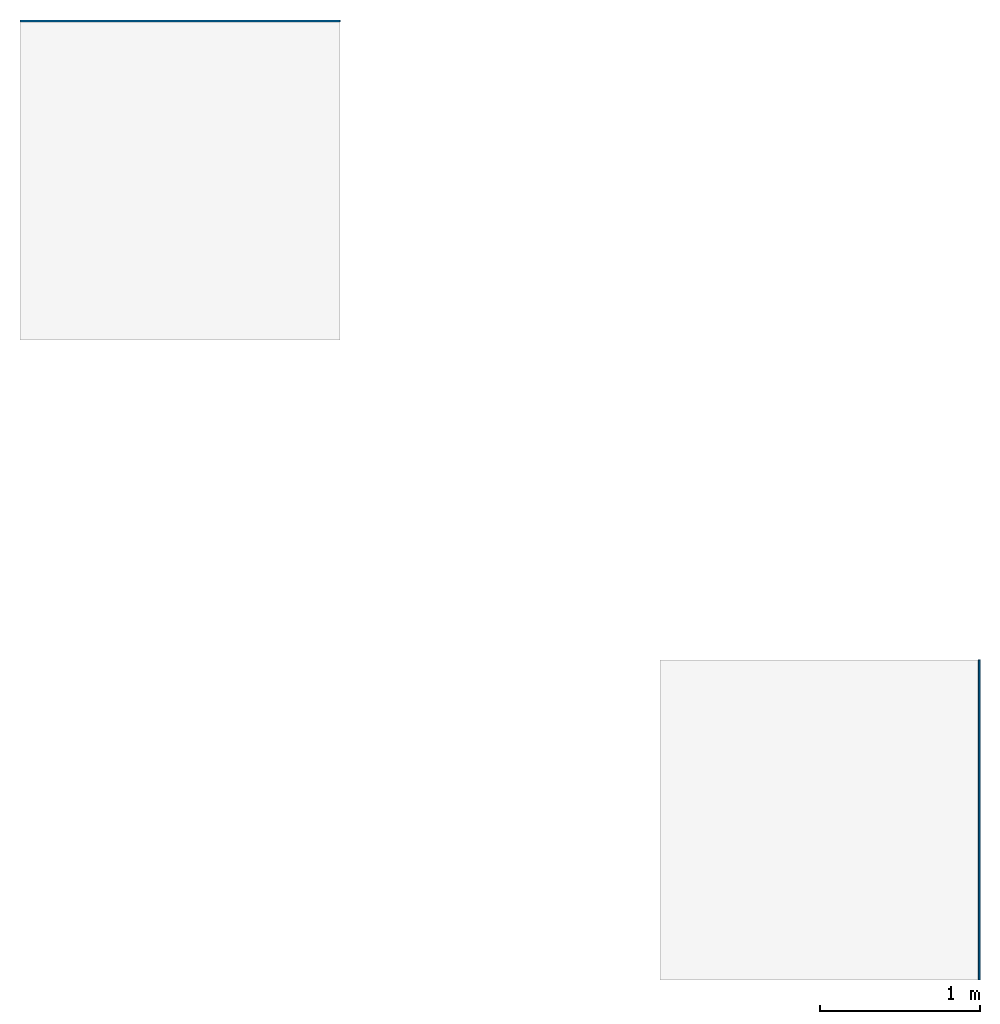
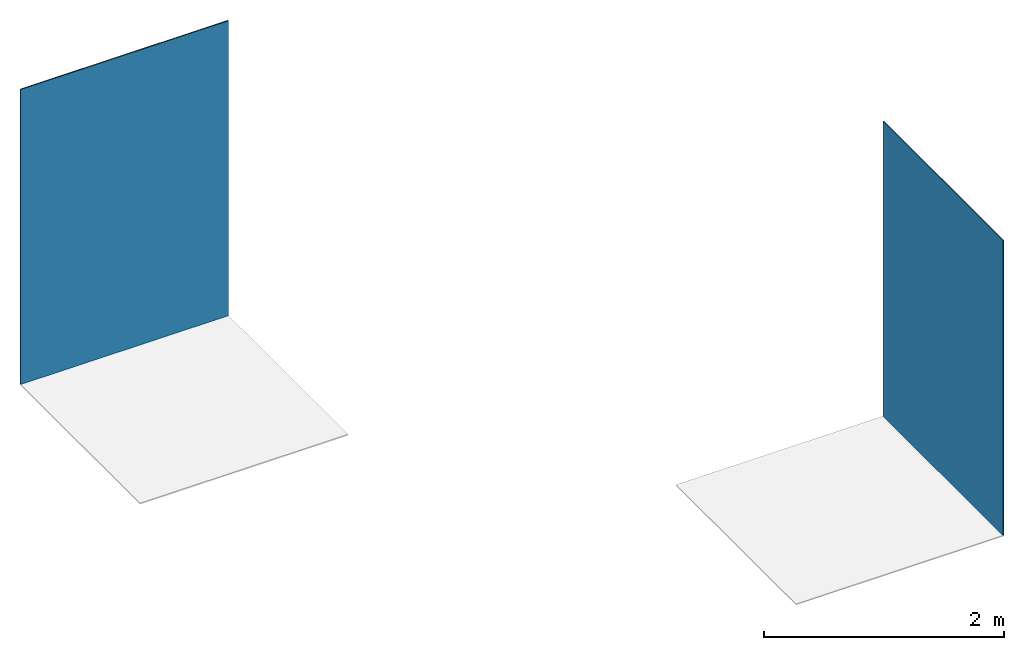
# One storey, part 1 of 2: 2 walls.
"""IFC2X3 building model written with IfcOpenShell, lengths in millimetres."""

from ifc_helpers import new_model, entity, si_unit, converted_unit, derived_unit, direction, frame, frame_2d, origin, place, context, subcontext, project, spatial, rectangle, extrude, material, layer, layer_set, layer_usage, type_object, element, save


model = new_model("IFC2X3")

# Units and contexts
model_context = context("Model", 3, precision=0.01, world=origin(), true_north=direction((6.12303176911189e-17, 1.0)))
body_context = subcontext(model_context, "Body", "Model", "MODEL_VIEW")
ifc_project = project(units=[si_unit("LENGTHUNIT", "METRE", prefix="MILLI"), si_unit("AREAUNIT", "SQUARE_METRE"), si_unit("VOLUMEUNIT", "CUBIC_METRE"), converted_unit("PLANEANGLEUNIT", "DEGREE", entity("IfcRatioMeasure", 0.0174532925199433), si_unit("PLANEANGLEUNIT", "RADIAN"), dimensions=[0, 0, 0, 0, 0, 0, 0]), si_unit("MASSUNIT", "GRAM", prefix="KILO"), derived_unit("MASSDENSITYUNIT", [(si_unit("MASSUNIT", "GRAM", prefix="KILO"), 1), (si_unit("LENGTHUNIT", "METRE"), -3)]), si_unit("TIMEUNIT", "SECOND"), si_unit("FREQUENCYUNIT", "HERTZ"), si_unit("THERMODYNAMICTEMPERATUREUNIT", "DEGREE_CELSIUS"), derived_unit("THERMALTRANSMITTANCEUNIT", [(si_unit("MASSUNIT", "GRAM", prefix="KILO"), 1), (si_unit("THERMODYNAMICTEMPERATUREUNIT", "KELVIN"), -1), (si_unit("TIMEUNIT", "SECOND"), -3)]), derived_unit("VOLUMETRICFLOWRATEUNIT", [(si_unit("LENGTHUNIT", "METRE"), 3), (si_unit("TIMEUNIT", "SECOND"), -1)]), si_unit("ELECTRICCURRENTUNIT", "AMPERE"), si_unit("ELECTRICVOLTAGEUNIT", "VOLT"), si_unit("POWERUNIT", "WATT"), si_unit("FORCEUNIT", "NEWTON", prefix="KILO"), si_unit("ILLUMINANCEUNIT", "LUX"), si_unit("LUMINOUSFLUXUNIT", "LUMEN"), si_unit("LUMINOUSINTENSITYUNIT", "CANDELA"), derived_unit("USERDEFINED", [(si_unit("MASSUNIT", "GRAM", prefix="KILO"), -1), (si_unit("LENGTHUNIT", "METRE"), -2), (si_unit("TIMEUNIT", "SECOND"), 3), (si_unit("LUMINOUSFLUXUNIT", "LUMEN"), 1)]), derived_unit("LINEARVELOCITYUNIT", [(si_unit("LENGTHUNIT", "METRE"), 1), (si_unit("TIMEUNIT", "SECOND"), -1)]), si_unit("PRESSUREUNIT", "PASCAL"), derived_unit("USERDEFINED", [(si_unit("LENGTHUNIT", "METRE"), -2), (si_unit("MASSUNIT", "GRAM", prefix="KILO"), 1), (si_unit("TIMEUNIT", "SECOND"), -2)])], contexts=[model_context])

# Site, building, storey
site_placement = place(None, origin())
site = spatial("IfcSite", under=ifc_project, at=site_placement, CompositionType="ELEMENT")
building_placement = place(site_placement, origin())
building = spatial("IfcBuilding", under=site, at=building_placement, CompositionType="ELEMENT")
storey_placement = place(building_placement, origin())
storey = spatial("IfcBuildingStorey", under=building, at=storey_placement, Name="Level 1", CompositionType="ELEMENT", Elevation=0.0)

# Walls
ifc_material_1 = material()
ifc_layer_1 = layer(ifc_material_1, 10.5)
ifc_layer_set_1 = layer_set([ifc_layer_1])
ifc_layer_usage_1 = layer_usage(ifc_layer_set_1, "AXIS2", "POSITIVE", -5.25)
wall_type_1 = type_object("IfcWallType", PredefinedType="STANDARD", material=ifc_layer_set_1)
wall_1_placement = place(storey_placement, frame((3521.82742659013, -2501.98267476881, 0.0), z_axis=(0.0, 0.0, 1.0), x_axis=(0.0, -1.0, 0.0)))
element("IfcWallStandardCase", 1, at=wall_1_placement, inside=storey, type_object=wall_type_1, material=ifc_layer_usage_1, context=body_context, shape_type="SweptSolid", body=[
    extrude(rectangle(XDim=2000.0, YDim=10.4999999999998, at=frame_2d((1000.0, 7.54951656745106e-15), x_axis=(-1.0, 0.0))), origin(), (0.0, 0.0, 1.0), 3000.00000000014),
])
ifc_material_2 = material()
ifc_layer_2 = layer(ifc_material_2, 11.2)
ifc_layer_set_2 = layer_set([ifc_layer_2])
ifc_layer_usage_2 = layer_usage(ifc_layer_set_2, "AXIS2", "POSITIVE", -5.6)
wall_type_2 = type_object("IfcWallType", PredefinedType="STANDARD", material=ifc_layer_set_2)
wall_2_placement = place(storey_placement, frame((-2472.92257340987, 1492.41732523118, 0.0)))
element("IfcWallStandardCase", 2, at=wall_2_placement, inside=storey, type_object=wall_type_2, material=ifc_layer_usage_2, context=body_context, shape_type="SweptSolid", body=[
    extrude(rectangle(XDim=2000.0, YDim=11.2000000000002, at=frame_2d((1000.0, 3.10862446895044e-14), x_axis=(-1.0, 0.0))), origin(), (0.0, 0.0, 1.0), 3000.00000000014),
])

save(model, "model.ifc")
